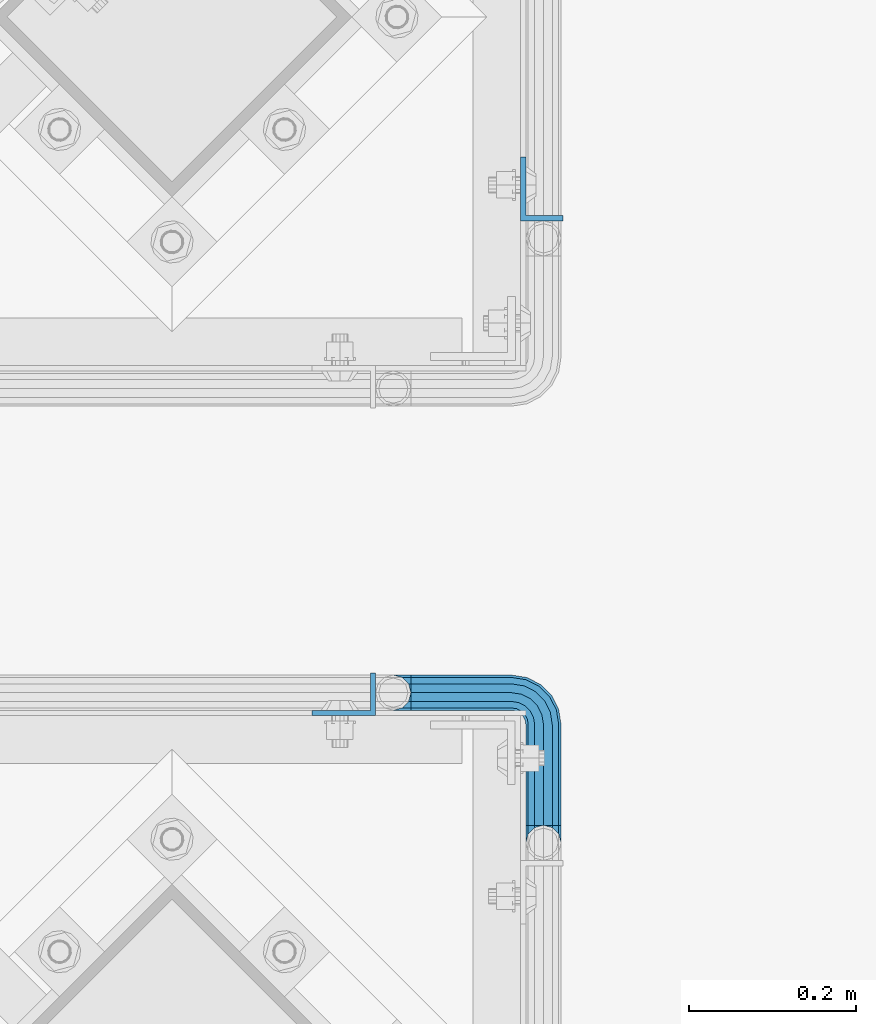
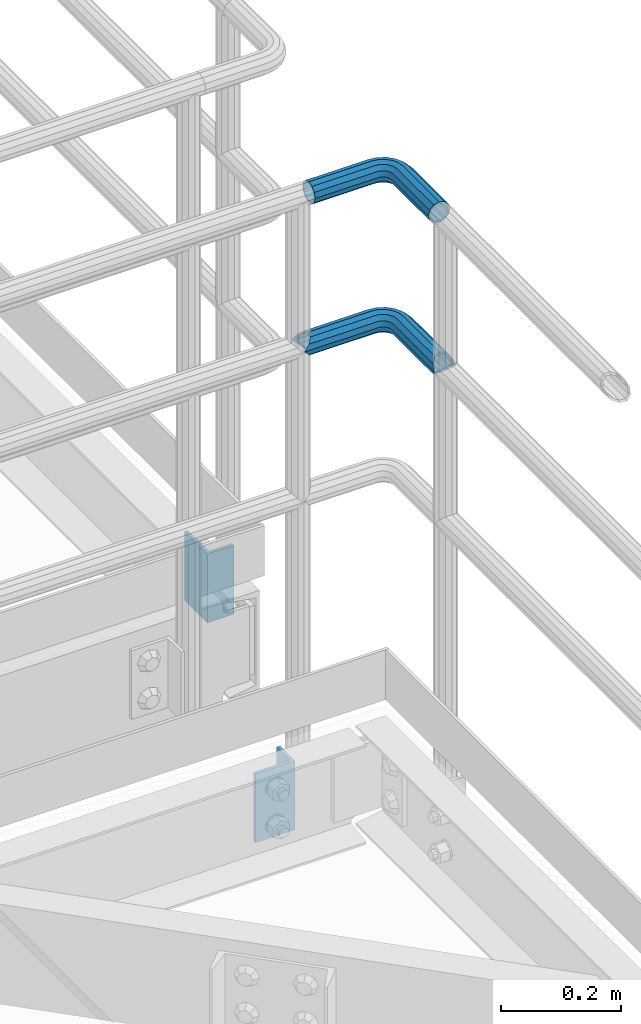
# One storey, part 1121 of 1876: 4 beams, 2 elements without a shape of their own.
"""IFC2X3 building model written with IfcOpenShell, lengths in millimetres."""

from ifc_helpers import new_model, si_unit, frame, origin_with_axes, place, context, subcontext, project, spatial, faceted_brep, material, type_object, element, aggregate, save


model = new_model("IFC2X3")

# Units and contexts
model_context = context("Model", 3, precision=1e-05, world=origin_with_axes())
body_context = subcontext(model_context, "Body", "Model", "MODEL_VIEW")
ifc_project = project(units=[si_unit("LENGTHUNIT", "METRE", prefix="MILLI"), si_unit("AREAUNIT", "SQUARE_METRE"), si_unit("VOLUMEUNIT", "CUBIC_METRE"), si_unit("MASSUNIT", "GRAM", prefix="KILO"), si_unit("TIMEUNIT", "SECOND"), si_unit("PLANEANGLEUNIT", "RADIAN"), si_unit("SOLIDANGLEUNIT", "STERADIAN"), si_unit("THERMODYNAMICTEMPERATUREUNIT", "DEGREE_CELSIUS"), si_unit("LUMINOUSINTENSITYUNIT", "LUMEN")], contexts=[model_context])

# Site, building, storey
site_placement = place(None, origin_with_axes())
site = spatial("IfcSite", under=ifc_project, at=site_placement, CompositionType="ELEMENT")
building_placement = place(site_placement, origin_with_axes())
building = spatial("IfcBuilding", under=site, at=building_placement, Name="Undefined", CompositionType="ELEMENT")
storey_placement = place(building_placement, origin_with_axes())
storey = spatial("IfcBuildingStorey", under=building, at=storey_placement, Name="Undefined", CompositionType="ELEMENT", Elevation=0.0)

# Assembly, beams
assembly_1_placement = place(storey_placement, origin_with_axes())
assembly_1 = element("IfcElementAssembly", 1, at=assembly_1_placement, inside=storey, Name="HANDRAIL", AssemblyPlace="NOTDEFINED", PredefinedType="RIGID_FRAME")
ifc_material_1 = material()
beam_type_1 = type_object("IfcBeamType", Name="PIPE1-1/4STD", PredefinedType="NOTDEFINED")
beam_1_placement = place(assembly_1_placement, frame((6845.30143150122, -11745.4324531237, 8785.225), z_axis=(0.0, 0.0, -1.0), x_axis=(1.0, 0.0, 0.0)))
beam_1 = element("IfcBeam", 2, at=beam_1_placement, type_object=beam_type_1, material=ifc_material_1, Name="HANDRAIL", ObjectType="PIPE1-1/4STD", context=body_context, shape_type="Brep", body=[
    faceted_brep([(9.09494701772928e-13, 21.0820000000003, 0.0), (10.5409999957128, 18.2575475579433, -10.5409999999993), (10.5409999999983, 18.2575475625836, 10.5410000000011), (10.5409999999983, -18.2575475625836, 10.5410000000011), (10.5409999957128, -18.2575475672238, -10.5409999999993), (9.09494701772928e-13, -21.0820000000003, 0.0), (18.2575475625817, -10.5410000000011, 18.2575475625836), (18.2575475625817, -10.5409999999974, 13.3999612267289), (13.6205863358537, -15.1779612267255, 8.76300000000083), (11.2725475625793, -17.5259999999998, 0.0), (13.6205863358537, -15.1779612267255, -8.76299999999901), (18.2575475625817, -10.5409999999974, -13.3999612267271), (18.2575475625817, -10.5410000000011, -18.2575475625836), (21.0819999999985, 0.0, -17.5259999999998), (21.0819999999985, 0.0, -21.0819999999985), (18.7339612267233, -8.76300000000083, -15.1779612267255), (18.7339612267251, 8.76299999999901, -15.1779612267255), (18.2575475625817, 10.5410000000011, -13.3999612267235), (18.2575475625817, 10.5409999999993, -18.2575475625836), (13.6205863358573, 15.1779612267255, -8.76299999999901), (11.2725475625839, 17.5259999999998, 0.0), (13.6205863358573, 15.1779612267255, 8.76300000000083), (18.2575475625817, 10.5410000000011, 13.3999612267253), (18.2575475625817, 10.5409999999993, 18.2575475625836), (18.7339612267251, 8.76299999999901, 15.1779612267273), (21.0819999999985, 1.81898940354586e-12, 17.5259999999998), (21.0819999999985, 1.81898940354586e-12, 21.0820000000003), (18.7339612267233, -8.76300000000083, 15.1779612267273), (141.729133605958, -8.76300000000265, 15.177961226731), (141.729133605958, -3.63797880709171e-12, 17.5260000000035), (153.502680620123, 1.86474665447895, 17.5259999999998), (156.210596541831, -6.46936159781399, 15.1779612267255), (141.729133605958, -15.1779612267292, 8.76300000000447), (158.192928579147, -12.5703522742733, 8.76300000000083), (141.729133605958, -17.5260000000035, 3.63797880709171e-12), (158.91851246354, -14.8034698501087, 0.0), (141.729133605959, -15.1779612267292, -8.76299999999537), (158.192928579147, -12.5703522742733, -8.76300000000083), (141.729133605959, -8.76300000000265, -15.1779612267219), (156.210596541831, -6.46936159781399, -15.1779612267255), (141.729133605959, -3.63797880709171e-12, -17.5259999999962), (153.502680620123, 1.86474665447895, -17.5259999999998), (141.72913360596, 8.76299999999719, -15.1779612267219), (150.794764698415, 10.1988549067737, -15.1779612267255), (141.72913360596, 15.1779612267237, -8.76299999999537), (148.8124326611, 16.2998455832312, -8.76300000000083), (141.729133605959, 17.525999999998, 3.63797880709171e-12), (148.086848776707, 18.5329631590685, 0.0), (141.729133605959, 15.1779612267237, 8.76300000000447), (148.8124326611, 16.2998455832312, 8.76300000000083), (141.729133605959, 8.76299999999719, 15.177961226731), (150.794764698415, 10.1988549067737, 15.1779612267255), (171.066132080078, 38.0999984741266, -15.1779612267255), (179.829132080078, 38.0999984741266, -17.5259999999998), (179.829132080079, 158.749951173106, -17.5259999999998), (171.066132080079, 161.097991264016, -15.1779612267255), (198.086679642661, 38.0999984741266, -10.5409999999993), (190.370132080077, 38.0999984741266, -18.2575475625836), (190.370132080079, 161.574403610522, -18.2575475625836), (198.086679642663, 169.290951173107, -10.5409999999993), (200.911132080079, 38.0999984741266, 0.0), (200.911136997563, 179.831951173106, 0.0), (198.086679642663, 169.290951173107, 10.5409999999993), (198.086679642661, 38.0999984741266, 10.5409999999993), (190.370132080077, 38.0999984741266, 18.2575475625836), (190.370132080079, 161.574403610522, 18.2575475625836), (179.829132080078, 38.0999984741266, 21.0820000000003), (179.829132080079, 158.749951173106, 21.0820000000003), (141.729133605959, 18.2575475625799, 10.5410000000047), (141.729133605959, 21.0819999999967, 3.63797880709171e-12), (141.72913360596, 18.2575475625799, -10.5409999999956), (141.72913360596, 10.5409999999974, -18.2575475625799), (141.729133605959, -3.63797880709171e-12, -21.0819999999949), (141.729133605959, -10.5410000000029, -18.2575475625799), (141.729133605959, -18.2575475625872, -10.5409999999956), (141.729133605958, -21.0820000000022, 3.63797880709171e-12), (141.729133605958, -18.2575475625872, 10.5410000000047), (141.729133605958, -10.5410000000029, 18.2575475625872), (141.729133605958, -3.63797880709171e-12, 21.082000000004), (141.729133605959, 10.5409999999974, 18.2575475625872), (150.245332482416, 11.8898333927464, 18.2575475625836), (147.860788147675, 19.2287062354426, 10.5409999999993), (146.987984344709, 21.9149201310138, 0.0), (147.860788147675, 19.2287062354426, -10.5409999999993), (150.245332482416, 11.8898333927464, -18.2575475625836), (153.502680620123, 1.86474665447895, -21.0820000000003), (156.760028757831, -8.16034008378665, -18.2575475625836), (159.144573092572, -15.4992129264829, -10.5409999999993), (160.017376895537, -18.1854268220541, 0.0), (159.144573092572, -15.4992129264829, 10.5409999999993), (156.760028757831, -8.16034008378665, 18.2575475625836), (153.502680620123, 1.86474665447895, 21.0820000000003), (164.123750821417, 7.27645222290812, 21.0820000000003), (157.927906477001, 15.8043003606126, 18.2575475625836), (170.319595165834, -1.25139591479638, 18.2575475625836), (174.855268021735, -7.49421403082852, 10.5409999999993), (176.51543951025, -9.77924405250269, 0.0), (174.855268021735, -7.49421403082852, -10.5409999999993), (170.319595165834, -1.25139591479638, -18.2575475625836), (164.123750821417, 7.27645222290812, -21.0820000000003), (157.927906477001, 15.8043003606126, -18.2575475625836), (153.3922336211, 22.0471184766448, -10.5409999999993), (151.732062132584, 24.3321484983171, 0.0), (153.3922336211, 22.0471184766448, 10.5409999999993), (164.024831719472, 21.9012256030837, 18.2575475625836), (157.782013603441, 26.4368984589855, 10.5409999999993), (172.552679857177, 15.7053812586691, 21.0820000000003), (181.080527994883, 9.50953691425275, 18.2575475625836), (187.323346110915, 4.97386405835096, 10.5409999999993), (189.608376132588, 3.31369256983635, 0.0), (187.323346110915, 4.97386405835096, -10.5409999999993), (181.080527994883, 9.50953691425275, -18.2575475625836), (172.552679857177, 15.7053812586691, -21.0820000000003), (164.024831719472, 21.9012256030837, -18.2575475625836), (157.782013603441, 26.4368984589855, -10.5409999999993), (155.496983581766, 28.0970699475001, 0.0), (160.600425844642, 31.9683439324108, 10.5409999999993), (157.914211949071, 32.8411477353766, 0.0), (167.939298687338, 29.583799597669, 18.2575475625836), (177.964385425605, 26.3264514599632, 21.0820000000003), (187.989472163872, 23.0691033222574, 18.2575475625836), (195.328345006568, 20.6845589875156, 10.5409999999993), (198.014558902139, 19.8117551845498, 0.0), (195.328345006568, 20.6845589875156, -10.5409999999993), (187.989472163872, 23.0691033222574, -18.2575475625836), (177.964385425605, 26.3264514599632, -21.0820000000003), (167.939298687338, 29.583799597669, -18.2575475625836), (160.600425844642, 31.9683439324108, -10.5409999999993), (158.747132080079, 38.0999984741266, 0.0), (161.571584517495, 38.0999984741266, -10.5409999999993), (161.571584517495, 38.0999984741266, 10.5409999999993), (169.288132080078, 38.0999984741266, 18.2575475625836), (179.829132080078, 38.0999984741266, -21.0820000000003), (169.288132080078, 38.0999984741266, -18.2575475625836), (161.571584517495, 169.290951173107, -10.5409999999993), (169.288132080079, 161.574403610522, -18.2575475625836), (179.829132080079, 158.749951173106, -21.0820000000003), (190.370136997562, 161.574403610522, -13.399956309242), (188.592132080079, 161.097988628744, -15.1779612267255), (188.592132080077, 38.0999984741266, -15.1779612267255), (195.007093306804, 38.0999984741266, -8.76300000000083), (195.007093306805, 166.211359919766, -8.76300000000083), (197.355132080079, 38.0999984741266, 0.0), (197.355132080079, 168.55939869304, 0.0), (195.007093306804, 38.0999984741266, 8.76300000000083), (195.007093306805, 166.211359919766, 8.76300000000083), (190.370136997562, 161.574403610522, 13.399956309242), (188.592132080077, 38.0999984741266, 15.1779612267255), (188.592132080079, 161.097988628744, 15.1779612267255), (179.829132080079, 158.749951173106, 17.5259999999998), (179.829132080078, 38.0999984741266, 17.5259999999998), (171.066132080078, 38.0999984741266, 15.1779612267255), (171.066132080079, 161.097991264016, 15.1779612267255), (162.303132080078, 38.0999984741266, 0.0), (164.651170853352, 38.0999984741266, -8.76300000000083), (164.651170853353, 166.211369754732, -8.76300000000083), (162.303132080079, 168.559408528006, 0.0), (164.651170853352, 38.0999984741266, 8.76300000000083), (164.651170853353, 166.211369754732, 8.76300000000083), (169.288136997562, 161.574403610522, 13.3999661442085), (169.288132080079, 161.574403610522, 18.2575475625836), (161.571584517495, 169.290951173107, 10.5409999999993), (158.747132080079, 179.831954956055, 0.0), (169.288136997562, 161.574403610522, -13.3999661442085), (169.630277173311, 29.0343673816715, -15.1779612267255), (163.529286496852, 31.0166994189858, -8.76300000000083), (177.964385425605, 26.3264514599632, -17.5259999999998), (186.298493677899, 23.6185355382549, -15.1779612267255), (192.399484354358, 21.6362035009406, -8.76300000000083), (194.632601930193, 20.9106196165467, 0.0), (192.399484354358, 21.6362035009406, 8.76300000000083), (186.298493677899, 23.6185355382549, 15.1779612267255), (177.964385425605, 26.3264514599632, 17.5259999999998), (169.630277173311, 29.0343673816715, 15.1779612267255), (163.529286496852, 31.0166994189858, 8.76300000000083), (161.296168921016, 31.7422833033779, 0.0), (160.273451284794, 24.626763027607, -8.76300000000083), (158.373848013764, 26.0069055903477, 0.0), (165.46326393547, 20.8561434245075, -15.1779612267255), (172.552679857177, 15.7053812586691, -17.5259999999998), (179.642095778884, 10.5546190928289, -15.1779612267255), (184.831908429562, 6.78399948973129, -8.76300000000083), (186.731511700591, 5.40385692698874, 0.0), (184.831908429562, 6.78399948973129, 8.76300000000083), (179.642095778884, 10.5546190928289, 15.1779612267255), (172.552679857177, 15.7053812586691, 17.5259999999998), (165.46326393547, 20.8561434245075, 15.1779612267255), (160.273451284794, 24.626763027607, 8.76300000000083), (153.822226489737, 21.45528406632, 0.0), (155.202369052478, 19.5556807952908, 8.76300000000083), (155.202369052478, 19.5556807952908, -8.76300000000083), (158.972988655577, 14.3658681446141, -15.1779612267255), (164.123750821417, 7.27645222290812, -17.5259999999998), (169.274512987257, 0.187036301200351, -15.1779612267255), (173.045132590356, -5.00277634947633, -8.76300000000083), (174.425275153098, -6.9023796205056, 0.0), (173.045132590356, -5.00277634947633, 8.76300000000083), (169.274512987257, 0.18703630120217, 15.1779612267255), (164.123750821417, 7.27645222290812, 17.5259999999998), (158.972988655577, 14.3658681446141, 15.1779612267255)], [[[0, 1, 2]], [[3, 4, 5]], [[6, 7, 8, 9, 10, 11, 12, 4, 3]], [[13, 14, 12, 11, 15]], [[16, 17, 18, 14, 13]], [[2, 1, 18, 17, 19, 20, 21, 22, 23]], [[23, 22, 24, 25, 26]], [[26, 25, 27, 7, 6]], [[28, 29, 30, 31]], [[32, 28, 31, 33]], [[34, 32, 33, 35]], [[36, 34, 35, 37]], [[38, 36, 37, 39]], [[40, 38, 39, 41]], [[42, 40, 41, 43]], [[44, 42, 43, 45]], [[46, 44, 45, 47]], [[48, 46, 47, 49]], [[50, 48, 49, 51]], [[52, 53, 54, 55]], [[56, 57, 58, 59]], [[60, 56, 59, 61]], [[61, 59, 62]], [[63, 60, 61, 62]], [[64, 63, 62, 65]], [[66, 64, 65, 67]], [[68, 69, 0, 2]], [[69, 70, 1, 0]], [[70, 71, 18, 1]], [[71, 72, 14, 18]], [[72, 73, 12, 14]], [[73, 74, 4, 12]], [[74, 75, 5, 4]], [[75, 76, 3, 5]], [[76, 77, 6, 3]], [[77, 78, 26, 6]], [[78, 79, 23, 26]], [[79, 68, 2, 23]], [[68, 79, 80, 81]], [[69, 68, 81, 82]], [[70, 69, 82, 83]], [[71, 70, 83, 84]], [[72, 71, 84, 85]], [[73, 72, 85, 86]], [[74, 73, 86, 87]], [[75, 74, 87, 88]], [[76, 75, 88, 89]], [[77, 76, 89, 90]], [[78, 77, 90, 91]], [[79, 78, 91, 80]], [[91, 92, 93, 80]], [[90, 94, 92, 91]], [[89, 95, 94, 90]], [[88, 96, 95, 89]], [[87, 97, 96, 88]], [[86, 98, 97, 87]], [[85, 99, 98, 86]], [[84, 100, 99, 85]], [[83, 101, 100, 84]], [[82, 102, 101, 83]], [[81, 103, 102, 82]], [[80, 93, 103, 81]], [[93, 104, 105, 103]], [[92, 106, 104, 93]], [[94, 107, 106, 92]], [[95, 108, 107, 94]], [[96, 109, 108, 95]], [[97, 110, 109, 96]], [[98, 111, 110, 97]], [[99, 112, 111, 98]], [[100, 113, 112, 99]], [[101, 114, 113, 100]], [[102, 115, 114, 101]], [[103, 105, 115, 102]], [[105, 116, 117, 115]], [[104, 118, 116, 105]], [[106, 119, 118, 104]], [[107, 120, 119, 106]], [[108, 121, 120, 107]], [[109, 122, 121, 108]], [[110, 123, 122, 109]], [[111, 124, 123, 110]], [[112, 125, 124, 111]], [[113, 126, 125, 112]], [[114, 127, 126, 113]], [[115, 117, 127, 114]], [[117, 128, 129, 127]], [[116, 130, 128, 117]], [[118, 131, 130, 116]], [[119, 66, 131, 118]], [[120, 64, 66, 119]], [[121, 63, 64, 120]], [[122, 60, 63, 121]], [[123, 56, 60, 122]], [[124, 57, 56, 123]], [[125, 132, 57, 124]], [[126, 133, 132, 125]], [[127, 129, 133, 126]], [[133, 129, 134, 135]], [[132, 133, 135, 136]], [[57, 132, 136, 58]], [[137, 58, 136, 54, 138]], [[53, 139, 138, 54]], [[138, 139, 140, 141, 137]], [[140, 142, 143, 141]], [[142, 144, 145, 143]], [[62, 59, 58, 137, 141, 143, 145, 146, 65]], [[144, 147, 148, 146, 145]], [[65, 146, 148, 149, 67]], [[147, 150, 149, 148]], [[150, 151, 152, 149]], [[153, 154, 155, 156]], [[157, 153, 156, 158]], [[151, 157, 158, 159, 152]], [[67, 149, 152, 159, 160]], [[131, 66, 67, 160]], [[130, 131, 160, 161]], [[128, 130, 161, 162]], [[129, 128, 162, 134]], [[161, 134, 162]], [[160, 159, 158, 156, 155, 163, 135, 134, 161]], [[54, 136, 135, 163, 55]], [[155, 154, 52, 55, 163]], [[164, 52, 154, 165]], [[166, 53, 52, 164]], [[167, 139, 53, 166]], [[168, 140, 139, 167]], [[169, 142, 140, 168]], [[170, 144, 142, 169]], [[171, 147, 144, 170]], [[172, 150, 147, 171]], [[173, 151, 150, 172]], [[174, 157, 151, 173]], [[175, 153, 157, 174]], [[165, 154, 153, 175]], [[176, 165, 175, 177]], [[178, 164, 165, 176]], [[179, 166, 164, 178]], [[180, 167, 166, 179]], [[181, 168, 167, 180]], [[182, 169, 168, 181]], [[183, 170, 169, 182]], [[184, 171, 170, 183]], [[185, 172, 171, 184]], [[186, 173, 172, 185]], [[187, 174, 173, 186]], [[177, 175, 174, 187]], [[188, 177, 187, 189]], [[190, 176, 177, 188]], [[191, 178, 176, 190]], [[192, 179, 178, 191]], [[193, 180, 179, 192]], [[194, 181, 180, 193]], [[195, 182, 181, 194]], [[196, 183, 182, 195]], [[197, 184, 183, 196]], [[198, 185, 184, 197]], [[199, 186, 185, 198]], [[189, 187, 186, 199]], [[49, 189, 199, 51]], [[47, 188, 189, 49]], [[45, 190, 188, 47]], [[43, 191, 190, 45]], [[41, 192, 191, 43]], [[39, 193, 192, 41]], [[37, 194, 193, 39]], [[35, 195, 194, 37]], [[33, 196, 195, 35]], [[31, 197, 196, 33]], [[30, 198, 197, 31]], [[51, 199, 198, 30]], [[29, 50, 51, 30]], [[50, 29, 25, 24]], [[21, 48, 50, 24, 22]], [[46, 48, 21, 20]], [[44, 46, 20, 19]], [[42, 44, 19, 17, 16]], [[40, 42, 16, 13]], [[38, 40, 13, 15]], [[10, 36, 38, 15, 11]], [[34, 36, 10, 9]], [[32, 34, 9, 8]], [[28, 32, 8, 7, 27]], [[29, 28, 27, 25]]]),
])
beam_2_placement = place(assembly_1_placement, frame((6866.33580650122, -11745.4324531237, 9090.025), z_axis=(0.0, 0.0, -1.0), x_axis=(1.0, 0.0, 0.0)))
beam_2 = element("IfcBeam", 3, at=beam_2_placement, type_object=beam_type_1, material=ifc_material_1, Name="HANDRAIL", ObjectType="PIPE1-1/4STD", context=body_context, shape_type="Brep", body=[
    faceted_brep([(9.09494701772928e-13, -21.0820000000003, 0.0), (0.0, -18.2575475625836, -10.5409999999993), (120.6947555542, -18.2575475625854, -10.5409999999956), (120.694755554199, -21.0820000000022, 3.63797880709171e-12), (0.0, -10.5410000000002, -18.2575475625836), (120.6947555542, -10.5410000000029, -18.2575475625799), (-4.28826751885936e-09, 0.0, -21.0820000000003), (120.694755554201, -3.63797880709171e-12, -21.0819999999967), (0.0, 10.5410000000002, -18.2575475625836), (120.694755554201, 10.5409999999974, -18.2575475625799), (0.0, 18.2575475625836, -10.5409999999993), (120.694755554201, 18.2575475625799, -10.5409999999956), (9.09494701772928e-13, 21.0820000000003, 0.0), (120.694755554201, 21.0819999999967, 3.63797880709171e-12), (0.0, 18.2575475625836, 10.5409999999993), (120.6947555542, 18.2575475625799, 10.5410000000047), (0.0, 10.5410000000002, 18.2575475625836), (120.6947555542, 10.5409999999974, 18.2575475625872), (0.0, 0.0, 21.0820000000003), (120.694755554199, -3.63797880709171e-12, 21.082000000004), (0.0, -10.5410000000002, 18.2575475625836), (120.694755554199, -10.5410000000029, 18.2575475625872), (0.0, -18.2575475625836, 10.5409999999993), (120.694755554199, -18.2575475625872, 10.5410000000047), (0.0, -17.5259999999998, 0.0), (0.0, -15.1779612267264, 8.76300000000083), (120.694755554199, -15.1779612267292, 8.76300000000447), (120.6947555542, -17.5260000000035, 3.63797880709171e-12), (0.0, -8.76299999999992, 15.1779612267255), (120.694755554199, -8.76300000000265, 15.177961226731), (0.0, 0.0, 17.5259999999998), (120.694755554199, -3.63797880709171e-12, 17.5260000000035), (0.0, 8.76299999999992, 15.1779612267255), (120.6947555542, 8.76299999999719, 15.177961226731), (0.0, 15.1779612267264, 8.76300000000083), (120.6947555542, 15.1779612267237, 8.76300000000447), (0.0, 17.5259999999998, 0.0), (120.694755554201, 17.525999999998, 3.63797880709171e-12), (0.0, 15.1779612267264, -8.76300000000083), (120.694755554201, 15.1779612267237, -8.76299999999537), (0.0, 8.76299999999992, -15.1779612267255), (120.694755554201, 8.76299999999719, -15.1779612267219), (0.0, 0.0, -17.5259999999998), (120.694755554201, -3.63797880709171e-12, -17.5259999999962), (0.0, -8.76299999999992, -15.1779612267255), (120.6947555542, -8.76300000000265, -15.1779612267219), (0.0, -15.1779612267264, -8.76300000000083), (120.6947555542, -15.1779612267292, -8.76299999999537), (138.982998843781, -18.1854268220541, 0.0), (138.110195040816, -15.4992129264829, 10.5409999999993), (135.725650706074, -8.16034008378665, 18.2575475625836), (132.468302568366, 1.86474665447895, 21.0820000000003), (129.210954430659, 11.8898333927464, 18.2575475625836), (126.826410095917, 19.2287062354426, 10.5409999999993), (125.953606292951, 21.9149201310138, 0.0), (126.826410095917, 19.2287062354426, -10.5409999999993), (129.210954430659, 11.8898333927464, -18.2575475625836), (132.468302568366, 1.86474665447895, -21.0820000000003), (135.725650706074, -8.16034008378665, -18.2575475625836), (138.110195040816, -15.4992129264829, -10.5409999999993), (137.884134411784, -14.8034698501087, 0.0), (137.158550527391, -12.5703522742733, -8.76300000000083), (135.176218490075, -6.46936159781399, -15.1779612267255), (132.468302568366, 1.86474665447895, -17.5259999999998), (129.760386646658, 10.1988549067737, -15.1779612267255), (127.778054609342, 16.299845583233, -8.76300000000083), (127.052470724949, 18.5329631590685, 0.0), (127.778054609342, 16.299845583233, 8.76300000000083), (129.760386646658, 10.1988549067737, 15.1779612267255), (132.468302568366, 1.86474665447895, 17.5259999999998), (135.176218490075, -6.46936159781399, 15.1779612267255), (137.158550527391, -12.5703522742733, 8.76300000000083), (149.285217114071, -1.25139591480001, -18.2575475625836), (153.820889969972, -7.49421403083397, -10.5409999999993), (143.089372769656, 7.27645222290448, -21.0820000000003), (136.89352842524, 15.8043003606108, -18.2575475625836), (132.357855569339, 22.0471184766429, -10.5409999999993), (130.697684080824, 24.3321484983171, 0.0), (132.357855569339, 22.0471184766429, 10.5409999999993), (136.89352842524, 15.8043003606108, 18.2575475625836), (143.089372769656, 7.27645222290448, 21.0820000000003), (149.285217114071, -1.25139591480001, 18.2575475625836), (153.820889969972, -7.49421403083397, 10.5409999999993), (155.481061458488, -9.77924405250633, 0.0), (152.010754538594, -5.00277634947997, 8.76300000000083), (153.390897101335, -6.90237962050924, 0.0), (148.240134935495, 0.187036301198532, 15.1779612267255), (143.089372769656, 7.27645222290448, 17.5259999999998), (137.938610603816, 14.3658681446123, 15.1779612267255), (134.167991000718, 19.5556807952889, 8.76300000000083), (132.787848437976, 21.45528406632, 0.0), (134.167991000718, 19.5556807952889, -8.76300000000083), (137.938610603816, 14.3658681446123, -15.1779612267255), (143.089372769656, 7.27645222290448, -17.5259999999998), (148.240134935495, 0.187036301198532, -15.1779612267255), (152.010754538594, -5.00277634947997, -8.76300000000083), (160.046149943126, 9.50953691425457, -18.2575475625836), (166.288968059158, 4.97386405835277, -10.5409999999993), (151.51830180542, 15.7053812586691, -21.0820000000003), (142.990453667714, 21.9012256030855, -18.2575475625836), (136.747635551682, 26.4368984589855, -10.5409999999993), (134.462605530009, 28.0970699475001, 0.0), (136.747635551682, 26.4368984589855, 10.5409999999993), (142.990453667714, 21.9012256030855, 18.2575475625836), (151.51830180542, 15.7053812586691, 21.0820000000003), (160.046149943126, 9.50953691425457, 18.2575475625836), (166.288968059158, 4.97386405835277, 10.5409999999993), (168.573998080832, 3.31369256983817, 0.0), (163.797530377805, 6.78399948973129, 8.76300000000083), (165.697133648835, 5.40385692699056, 0.0), (158.607717727127, 10.5546190928308, 15.1779612267255), (151.51830180542, 15.7053812586691, 17.5259999999998), (144.428885883713, 20.8561434245094, 15.1779612267255), (139.239073233036, 24.626763027607, 8.76300000000083), (137.339469962006, 26.0069055903477, 0.0), (139.239073233036, 24.626763027607, -8.76300000000083), (144.428885883713, 20.8561434245094, -15.1779612267255), (151.51830180542, 15.7053812586691, -17.5259999999998), (158.607717727127, 10.5546190928289, -15.1779612267255), (163.797530377805, 6.78399948973129, -8.76300000000083), (166.955094112114, 23.0691033222574, -18.2575475625836), (174.293966954811, 20.6845589875174, -10.5409999999993), (156.930007373847, 26.326451459965, -21.0820000000003), (146.90492063558, 29.5837995976708, -18.2575475625836), (139.566047792883, 31.9683439324108, -10.5409999999993), (136.879833897313, 32.8411477353766, 0.0), (139.566047792883, 31.9683439324108, 10.5409999999993), (146.90492063558, 29.5837995976708, 18.2575475625836), (156.930007373847, 26.326451459965, 21.0820000000003), (166.955094112114, 23.0691033222574, 18.2575475625836), (174.293966954811, 20.6845589875174, 10.5409999999993), (176.980180850382, 19.8117551845517, 0.0), (171.3651063026, 21.6362035009424, 8.76300000000083), (173.598223878436, 20.9106196165503, 0.0), (165.264115626142, 23.6185355382568, 15.1779612267255), (156.930007373847, 26.326451459965, 17.5259999999998), (148.595899121553, 29.0343673816715, 15.1779612267255), (142.494908445095, 31.0166994189858, 8.76300000000083), (140.261790869258, 31.7422833033797, 0.0), (142.494908445095, 31.0166994189858, -8.76300000000083), (148.595899121553, 29.0343673816715, -15.1779612267255), (156.930007373847, 26.326451459965, -17.5259999999998), (165.264115626142, 23.6185355382568, -15.1779612267255), (171.3651063026, 21.6362035009424, -8.76300000000083), (169.33575402832, 38.0999984741266, -18.2575475625836), (177.052301590903, 38.0999984741266, -10.5409999999993), (158.794754028319, 38.0999984741266, -21.0820000000003), (148.253754028319, 38.0999984741266, -18.2575475625836), (140.537206465736, 38.0999984741266, -10.5409999999993), (137.71275402832, 38.0999984741266, 0.0), (140.537206465736, 38.0999984741266, 10.5409999999993), (148.253754028319, 38.0999984741266, 18.2575475625836), (158.794754028319, 38.0999984741266, 21.0820000000003), (169.33575402832, 38.0999984741266, 18.2575475625836), (177.052301590903, 38.0999984741266, 10.5409999999993), (179.876754028321, 38.0999984741266, 0.0), (173.972715255046, 38.0999984741266, 8.76300000000083), (176.32075402832, 38.0999984741266, 0.0), (167.557754028319, 38.0999984741266, 15.1779612267255), (158.794754028319, 38.0999984741266, 17.5259999999998), (150.031754028319, 38.0999984741266, 15.1779612267255), (143.616792801594, 38.0999984741266, 8.76300000000083), (141.26875402832, 38.0999984741266, 0.0), (143.616792801594, 38.0999984741266, -8.76300000000083), (150.031754028319, 38.0999984741266, -15.1779612267255), (158.794754028319, 38.0999984741266, -17.5259999999998), (167.557754028319, 38.0999984741266, -15.1779612267255), (173.972715255046, 38.0999984741266, -8.76300000000083), (177.052301590904, 158.797576904297, -10.5409999999993), (179.876754028321, 158.797576904297, 0.0), (169.33575402832, 158.797576904297, -18.2575475625836), (158.79475402832, 158.797576904297, -21.0820000000003), (148.25375402832, 158.797576904297, -18.2575475625836), (140.537206465737, 158.797576904297, -10.5409999999993), (137.71275402832, 158.797576904297, 0.0), (140.537206465737, 158.797576904297, 10.5409999999993), (148.25375402832, 158.797576904297, 18.2575475625836), (158.79475402832, 158.797576904297, 21.0820000000003), (169.33575402832, 158.797576904297, 18.2575475625836), (177.052301590904, 158.797576904297, 10.5409999999993), (173.972715255047, 158.797576904297, 8.76300000000083), (176.32075402832, 158.797576904297, 0.0), (167.55775402832, 158.797576904297, 15.1779612267255), (158.79475402832, 158.797576904297, 17.5259999999998), (150.03175402832, 158.797576904297, 15.1779612267255), (143.616792801594, 158.797576904297, 8.76300000000083), (141.26875402832, 158.797576904297, 0.0), (143.616792801594, 158.797576904297, -8.76300000000083), (150.03175402832, 158.797576904297, -15.1779612267255), (158.79475402832, 158.797576904297, -17.5259999999998), (167.55775402832, 158.797576904297, -15.1779612267255), (173.972715255047, 158.797576904297, -8.76300000000083)], [[[0, 1, 2, 3]], [[1, 4, 5, 2]], [[4, 6, 7, 5]], [[6, 8, 9, 7]], [[8, 10, 11, 9]], [[10, 12, 13, 11]], [[12, 14, 15, 13]], [[14, 16, 17, 15]], [[16, 18, 19, 17]], [[18, 20, 21, 19]], [[20, 22, 23, 21]], [[22, 0, 3, 23]], [[24, 25, 26, 27]], [[25, 28, 29, 26]], [[28, 30, 31, 29]], [[30, 32, 33, 31]], [[32, 34, 35, 33]], [[34, 36, 37, 35]], [[36, 38, 39, 37]], [[38, 40, 41, 39]], [[40, 42, 43, 41]], [[42, 44, 45, 43]], [[44, 46, 47, 45]], [[46, 24, 27, 47]], [[22, 20, 18, 16, 14, 12, 10, 8, 6, 4, 1, 0], [46, 44, 42, 40, 38, 36, 34, 32, 30, 28, 25, 24]], [[23, 3, 48, 49]], [[21, 23, 49, 50]], [[19, 21, 50, 51]], [[17, 19, 51, 52]], [[15, 17, 52, 53]], [[13, 15, 53, 54]], [[11, 13, 54, 55]], [[9, 11, 55, 56]], [[7, 9, 56, 57]], [[5, 7, 57, 58]], [[2, 5, 58, 59]], [[3, 2, 59, 48]], [[47, 27, 60, 61]], [[45, 47, 61, 62]], [[43, 45, 62, 63]], [[41, 43, 63, 64]], [[39, 41, 64, 65]], [[37, 39, 65, 66]], [[35, 37, 66, 67]], [[33, 35, 67, 68]], [[31, 33, 68, 69]], [[29, 31, 69, 70]], [[26, 29, 70, 71]], [[27, 26, 71, 60]], [[58, 72, 73, 59]], [[57, 74, 72, 58]], [[56, 75, 74, 57]], [[55, 76, 75, 56]], [[54, 77, 76, 55]], [[53, 78, 77, 54]], [[52, 79, 78, 53]], [[51, 80, 79, 52]], [[50, 81, 80, 51]], [[49, 82, 81, 50]], [[48, 83, 82, 49]], [[59, 73, 83, 48]], [[71, 84, 85, 60]], [[70, 86, 84, 71]], [[69, 87, 86, 70]], [[68, 88, 87, 69]], [[67, 89, 88, 68]], [[66, 90, 89, 67]], [[65, 91, 90, 66]], [[64, 92, 91, 65]], [[63, 93, 92, 64]], [[62, 94, 93, 63]], [[61, 95, 94, 62]], [[60, 85, 95, 61]], [[72, 96, 97, 73]], [[74, 98, 96, 72]], [[75, 99, 98, 74]], [[76, 100, 99, 75]], [[77, 101, 100, 76]], [[78, 102, 101, 77]], [[79, 103, 102, 78]], [[80, 104, 103, 79]], [[81, 105, 104, 80]], [[82, 106, 105, 81]], [[83, 107, 106, 82]], [[73, 97, 107, 83]], [[84, 108, 109, 85]], [[86, 110, 108, 84]], [[87, 111, 110, 86]], [[88, 112, 111, 87]], [[89, 113, 112, 88]], [[90, 114, 113, 89]], [[91, 115, 114, 90]], [[92, 116, 115, 91]], [[93, 117, 116, 92]], [[94, 118, 117, 93]], [[95, 119, 118, 94]], [[85, 109, 119, 95]], [[96, 120, 121, 97]], [[98, 122, 120, 96]], [[99, 123, 122, 98]], [[100, 124, 123, 99]], [[101, 125, 124, 100]], [[102, 126, 125, 101]], [[103, 127, 126, 102]], [[104, 128, 127, 103]], [[105, 129, 128, 104]], [[106, 130, 129, 105]], [[107, 131, 130, 106]], [[97, 121, 131, 107]], [[108, 132, 133, 109]], [[110, 134, 132, 108]], [[111, 135, 134, 110]], [[112, 136, 135, 111]], [[113, 137, 136, 112]], [[114, 138, 137, 113]], [[115, 139, 138, 114]], [[116, 140, 139, 115]], [[117, 141, 140, 116]], [[118, 142, 141, 117]], [[119, 143, 142, 118]], [[109, 133, 143, 119]], [[120, 144, 145, 121]], [[122, 146, 144, 120]], [[123, 147, 146, 122]], [[124, 148, 147, 123]], [[125, 149, 148, 124]], [[126, 150, 149, 125]], [[127, 151, 150, 126]], [[128, 152, 151, 127]], [[129, 153, 152, 128]], [[130, 154, 153, 129]], [[131, 155, 154, 130]], [[121, 145, 155, 131]], [[132, 156, 157, 133]], [[134, 158, 156, 132]], [[135, 159, 158, 134]], [[136, 160, 159, 135]], [[137, 161, 160, 136]], [[138, 162, 161, 137]], [[139, 163, 162, 138]], [[140, 164, 163, 139]], [[141, 165, 164, 140]], [[142, 166, 165, 141]], [[143, 167, 166, 142]], [[133, 157, 167, 143]], [[155, 145, 168, 169]], [[145, 144, 170, 168]], [[144, 146, 171, 170]], [[146, 147, 172, 171]], [[147, 148, 173, 172]], [[148, 149, 174, 173]], [[149, 150, 175, 174]], [[150, 151, 176, 175]], [[151, 152, 177, 176]], [[152, 153, 178, 177]], [[153, 154, 179, 178]], [[154, 155, 169, 179]], [[157, 156, 180, 181]], [[156, 158, 182, 180]], [[158, 159, 183, 182]], [[159, 160, 184, 183]], [[160, 161, 185, 184]], [[161, 162, 186, 185]], [[162, 163, 187, 186]], [[163, 164, 188, 187]], [[164, 165, 189, 188]], [[165, 166, 190, 189]], [[166, 167, 191, 190]], [[167, 157, 181, 191]], [[170, 171, 172, 173, 174, 175, 176, 177, 178, 179, 169, 168], [182, 183, 184, 185, 186, 187, 188, 189, 190, 191, 181, 180]]]),
])
ifc_material_2 = material(Name="STEEL/A36")
beam_type_2 = type_object("IfcBeamType", Name="L3X2X1/4", PredefinedType="NOTDEFINED")
beam_3_placement = place(assembly_1_placement, frame((6786.11943150122, -11747.4644531238, 7966.075), z_axis=(-1.0, 0.0, 0.0), x_axis=(0.0, 0.0, -1.0)))
beam_3 = element("IfcBeam", 4, at=beam_3_placement, type_object=beam_type_2, material=ifc_material_2, Name="ANGLE", ObjectType="L3X2X1/4", context=body_context, shape_type="Brep", body=[
    faceted_brep([(0.0, 25.3999999999996, -38.1000000000004), (0.0, 25.3999999999996, 38.1000000000004), (139.7, 25.3999999999996, 38.1000000000004), (139.7, 25.3999999999996, -38.1000000000004), (0.0, 19.0500000000002, 38.1000000000004), (139.7, 19.0500000000002, 38.1000000000004), (0.0, 19.0500000000002, -31.75), (139.7, 19.0500000000002, -31.75), (0.0, -25.3999999999996, -31.75), (139.7, -25.3999999999996, -31.75), (0.0, -25.3999999999996, -38.1000000000004), (139.7, -25.3999999999996, -38.1000000000004)], [[[0, 1, 2, 3]], [[1, 4, 5, 2]], [[4, 6, 7, 5]], [[6, 8, 9, 7]], [[8, 10, 11, 9]], [[10, 0, 3, 11]], [[5, 7, 9, 11, 3, 2]], [[10, 8, 6, 4, 1, 0]]]),
])
aggregate(assembly_1, [beam_1, beam_2, beam_3])

# Assembly, beam
assembly_2_placement = place(storey_placement, origin_with_axes())
assembly_2 = element("IfcElementAssembly", 5, at=assembly_2_placement, inside=storey, Name="HANDRAIL", AssemblyPlace="NOTDEFINED", PredefinedType="RIGID_FRAME")
beam_4_placement = place(assembly_2_placement, frame((7023.10047584742, -11142.1823554687, 7966.075), z_axis=(0.0, 1.0, 0.0), x_axis=(0.0, 0.0, -1.0)))
beam_4 = element("IfcBeam", 6, at=beam_4_placement, type_object=beam_type_2, material=ifc_material_2, Name="ANGLE", ObjectType="L3X2X1/4", context=body_context, shape_type="Brep", body=[
    faceted_brep([(0.0, 25.3999999999996, -38.1000000000004), (0.0, 25.3999999999996, 38.1000000000004), (139.7, 25.3999999999996, 38.1000000000004), (139.7, 25.3999999999996, -38.1000000000004), (0.0, 19.0500000000002, 38.1000000000004), (139.7, 19.0500000000002, 38.1000000000004), (0.0, 19.0500000000002, -31.75), (139.7, 19.0500000000002, -31.75), (0.0, -25.3999999999996, -31.75), (139.7, -25.3999999999996, -31.75), (0.0, -25.3999999999996, -38.1000000000004), (139.7, -25.3999999999996, -38.1000000000004)], [[[0, 1, 2, 3]], [[1, 4, 5, 2]], [[4, 6, 7, 5]], [[6, 8, 9, 7]], [[8, 10, 11, 9]], [[10, 0, 3, 11]], [[5, 7, 9, 11, 3, 2]], [[10, 8, 6, 4, 1, 0]]]),
])
aggregate(assembly_2, [beam_4])

save(model, "model.ifc")
